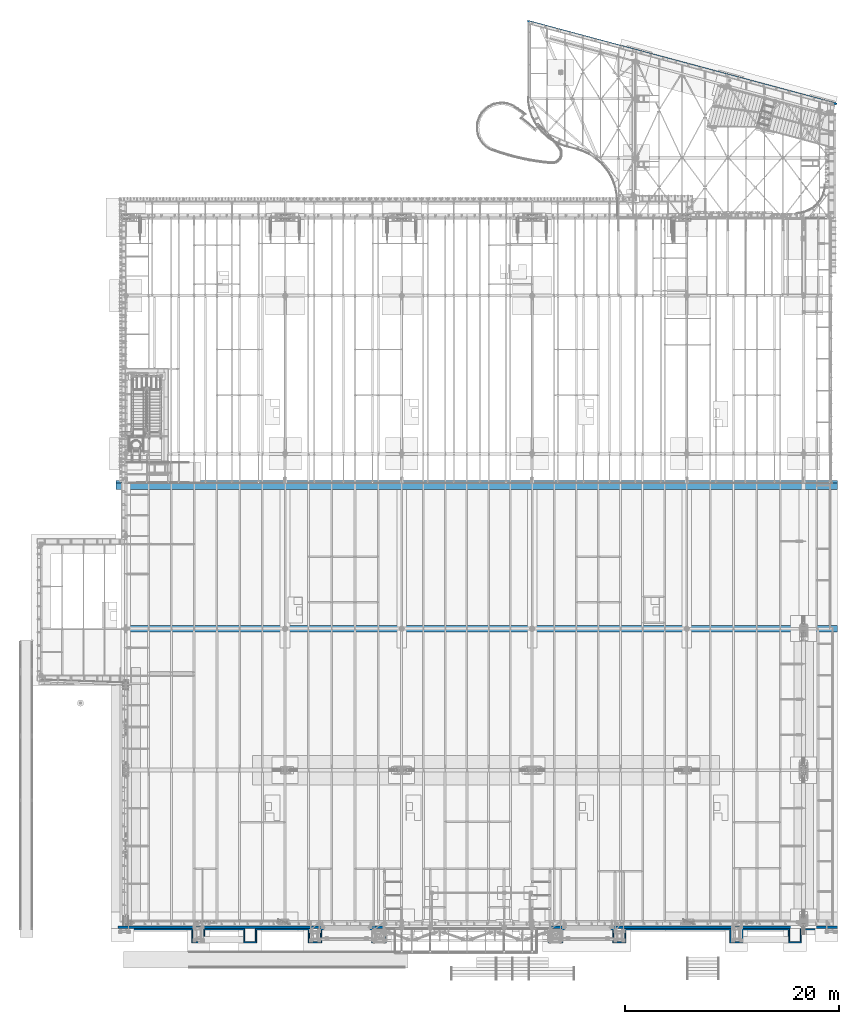
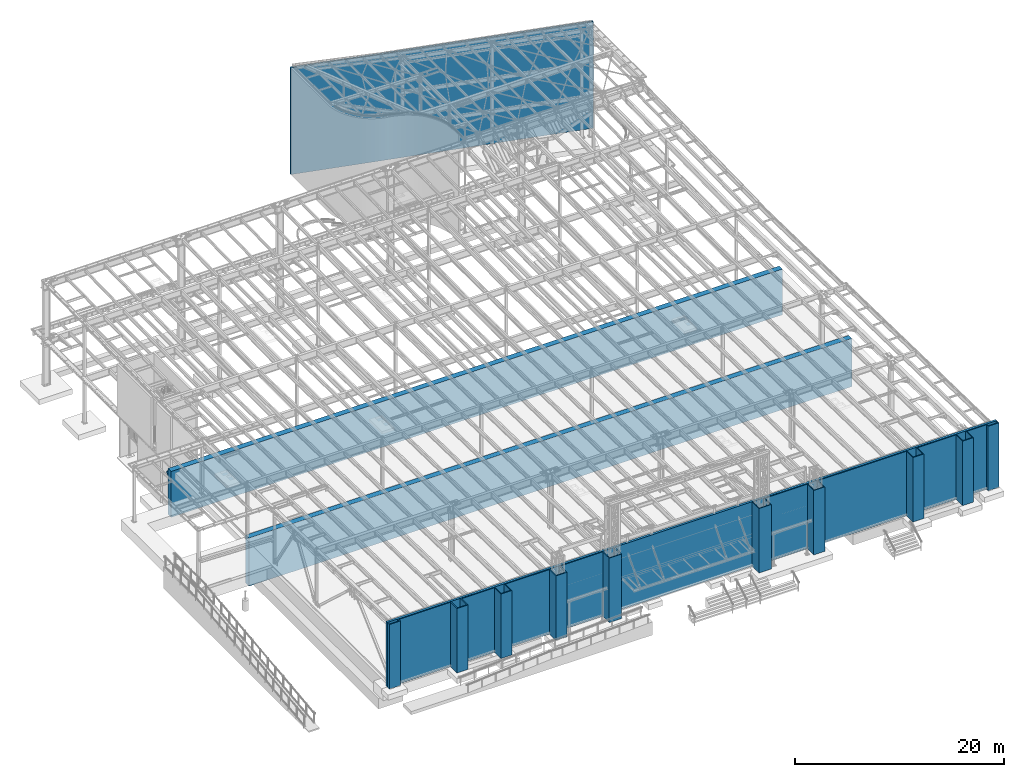
# One storey, part 1717 of 1763: 7 walls, 7 elements without a shape of their own.
"""IFC2X3 building model written with IfcOpenShell, lengths in millimetres."""

import ifcopenshell
import ifcopenshell.guid

model = None  # the IFC model being written
_history = None  # IfcOwnerHistory: only IFC2X3 demands one
_inside = {}  # id of a spatial element -> (the spatial element, [elements in it])
_under = {}  # id of a project, library or spatial element -> (it, [spatial elements below it])
_declared = {}  # id of a project -> (the project, [libraries it declares])
_typed = {}  # id of a type object -> (the type object, [elements of that type])
_made_of = {}  # id of a material, layer set ... -> (it, [elements and type objects made of it])


def new_model(schema):
    """Start an empty IFC model of exactly this schema.

    Asked for "IFC4X3", IfcOpenShell would pick the latest addendum, in which some entities
    have other attributes; the version numbers below select the first issue.
    IFC2X3 requires an IfcOwnerHistory on every rooted entity: one is made here for all.
    """
    global model, _history
    if schema == "IFC4X3":
        model = ifcopenshell.file(schema_version=(4, 3, 0, 0))
    else:
        model = ifcopenshell.file(schema=schema)
    _inside.clear()
    _under.clear()
    _declared.clear()
    _typed.clear()
    _made_of.clear()
    _history = None
    if model.schema == "IFC2X3":
        org = make("IfcOrganization", Name="unknown")
        user = make(
            "IfcPersonAndOrganization",
            ThePerson=make("IfcPerson", FamilyName="unknown"),
            TheOrganization=org,
        )
        app = make(
            "IfcApplication",
            ApplicationDeveloper=org,
            Version="unknown",
            ApplicationFullName="unknown",
            ApplicationIdentifier="unknown",
        )
        _history = make(
            "IfcOwnerHistory",
            OwningUser=user,
            OwningApplication=app,
            ChangeAction="ADDED",
            CreationDate=0,
        )
    return model


def make(cls, **values):
    """One entity of the class cls with the attributes given. An attribute that is None is left unset."""
    return model.create_entity(
        cls, **{name: value for name, value in values.items() if value is not None}
    )


def rooted(cls, **values):
    """An entity with a GlobalId (a new one), such as an element, a storey or a relation."""
    return make(cls, GlobalId=ifcopenshell.guid.new(), OwnerHistory=_history, **values)


def si_unit(unit_type, name, prefix=None):
    """IfcSIUnit, for example si_unit("LENGTHUNIT", "METRE", prefix="MILLI")."""
    return make("IfcSIUnit", UnitType=unit_type, Prefix=prefix, Name=name)


def assignment(units):
    """IfcUnitAssignment: the units of a project."""
    return None if units is None else make("IfcUnitAssignment", Units=units)


def point(xyz):
    """IfcCartesianPoint."""
    return None if xyz is None else make("IfcCartesianPoint", Coordinates=xyz)


def direction(xyz):
    """IfcDirection."""
    return None if xyz is None else make("IfcDirection", DirectionRatios=xyz)


def frame(location, z_axis=None, x_axis=None):
    """IfcAxis2Placement3D, a coordinate frame: its origin and axes. An axis left out is left unset."""
    return make(
        "IfcAxis2Placement3D",
        Location=point(location),
        Axis=direction(z_axis),
        RefDirection=direction(x_axis),
    )


def origin_with_axes():
    """The frame at (0, 0, 0) with the z axis (0, 0, 1) and the x axis (1, 0, 0) written out."""
    return frame((0.0, 0.0, 0.0), z_axis=(0.0, 0.0, 1.0), x_axis=(1.0, 0.0, 0.0))


def place(relative_to, where):
    """IfcLocalPlacement: puts the frame where relative to a parent placement (None: the world)."""
    return make(
        "IfcLocalPlacement", PlacementRelTo=relative_to, RelativePlacement=where
    )


def context(
    kind, dimensions, precision=None, world=None, true_north=None, identifier=None
):
    """IfcGeometricRepresentationContext, for example the 3D "Model" context."""
    return make(
        "IfcGeometricRepresentationContext",
        ContextIdentifier=identifier,
        ContextType=kind,
        CoordinateSpaceDimension=dimensions,
        Precision=precision,
        WorldCoordinateSystem=world,
        TrueNorth=true_north,
    )


def subcontext(parent, identifier, kind, view, scale=None):
    """IfcGeometricRepresentationSubContext, for example "Body" below "Model"."""
    return make(
        "IfcGeometricRepresentationSubContext",
        ContextIdentifier=identifier,
        ContextType=kind,
        ParentContext=parent,
        TargetScale=scale,
        TargetView=view,
    )


def project(units=None, contexts=None):
    """IfcProject with its units and contexts."""
    return rooted(
        "IfcProject",
        Name="project",
        RepresentationContexts=contexts,
        UnitsInContext=assignment(units),
    )


def spatial(cls, under=None, at=None, **own):
    """A site, building, storey or space (cls), placed at a placement, below another one or the project."""
    s = rooted(cls, ObjectPlacement=at, **own)
    if under is not None:
        _under.setdefault(under.id(), (under, []))[1].append(s)
    return s


def faces_of(points, faces, orient=None, outer=None):
    """IfcFace entities. A face is a list of loops; a loop is a list of indices into points, from 0.

    orient and outer hold one flag for each loop. By default every Orientation is true, the
    first loop of a face is its IfcFaceOuterBound and the others are IfcFaceBound.
    """
    made = []
    for i, loops in enumerate(faces):
        bounds = []
        for j, loop in enumerate(loops):
            is_outer = j == 0 if outer is None else outer[i][j]
            bounds.append(
                make(
                    "IfcFaceOuterBound" if is_outer else "IfcFaceBound",
                    Bound=make("IfcPolyLoop", Polygon=[points[k] for k in loop]),
                    Orientation=True if orient is None else orient[i][j],
                )
            )
        made.append(make("IfcFace", Bounds=bounds))
    return made


def faceted_brep(points, faces, orient=None, outer=None, voids=None):
    """IfcFacetedBrep: a solid bounded by flat faces; with voids (closed shells), ...WithVoids."""
    shared = [point(p) for p in points]
    hull = make("IfcClosedShell", CfsFaces=faces_of(shared, faces, orient, outer))
    if voids is None:
        return make("IfcFacetedBrep", Outer=hull)
    return make(
        "IfcFacetedBrepWithVoids",
        Outer=hull,
        Voids=[
            make(cls, CfsFaces=faces_of(shared, fs, o, b)) for cls, fs, o, b in voids
        ],
    )


def shape(context_of_items, identifier, shape_type, items):
    """IfcShapeRepresentation: the items that make up one representation, for example the "Body"."""
    return make(
        "IfcShapeRepresentation",
        ContextOfItems=context_of_items,
        RepresentationIdentifier=identifier,
        RepresentationType=shape_type,
        Items=items,
    )


def material(Name=None, Category=None):
    """IfcMaterial."""
    return make("IfcMaterial", Name=Name, Category=Category)


def made_of(thing, what):
    """Note that an element or type object is made of a material, layer set ...; save() writes the relation."""
    if what is not None:
        _made_of.setdefault(what.id(), (what, []))[1].append(thing)
    return thing


def type_object(cls, material=None, **own):
    """A type object (cls), such as IfcWallType, which elements share."""
    return made_of(rooted(cls, **own), material)


def element(
    cls,
    number,
    at=None,
    inside=None,
    cuts=None,
    type_object=None,
    material=None,
    context=None,
    identifier="Body",
    shape_type=None,
    held_by="IfcProductDefinitionShape",
    body=None,
    shapes=None,
    **own,
):
    """One element of the class cls, such as IfcWall. Its Tag is "e" and its number.

    at: its placement. inside: the storey or other place that contains it. cuts: it is an
    opening in that element (IfcRelVoidsElement). A single representation is given by context,
    identifier, shape_type and body (its items); several are given by shapes. held_by: the class
    of the entity that holds the representations. save() writes the other relations.
    """
    e = rooted(cls, Tag="e%d" % number, ObjectPlacement=at, **own)
    if body is not None:
        shapes = [shape(context, identifier, shape_type, body)]
    if shapes is not None:
        e.Representation = make(held_by, Representations=shapes)
    if inside is not None:
        _inside.setdefault(inside.id(), (inside, []))[1].append(e)
    if cuts is not None:
        rooted(
            "IfcRelVoidsElement", RelatingBuildingElement=cuts, RelatedOpeningElement=e
        )
    if type_object is not None:
        _typed.setdefault(type_object.id(), (type_object, []))[1].append(e)
    return made_of(e, material)


def aggregate(whole, parts):
    """IfcRelAggregates: a whole, such as a stair, and the parts it consists of."""
    return rooted("IfcRelAggregates", RelatingObject=whole, RelatedObjects=parts)


def save(model, path):
    """Write the relations noted so far, then the file.

    IfcRelAggregates (storeys below a building ...), IfcRelContainedInSpatialStructure (elements
    in a storey), IfcRelDefinesByType, IfcRelAssociatesMaterial and IfcRelDeclares: one each for
    every whole, place, type object, material and project.
    """
    for whole, parts in _under.values():
        aggregate(whole, parts)
    for where, things in _inside.values():
        rooted(
            "IfcRelContainedInSpatialStructure",
            RelatedElements=things,
            RelatingStructure=where,
        )
    for kind, things in _typed.values():
        rooted("IfcRelDefinesByType", RelatedObjects=things, RelatingType=kind)
    for what, things in _made_of.values():
        rooted("IfcRelAssociatesMaterial", RelatedObjects=things, RelatingMaterial=what)
    for by, libraries in _declared.values():
        rooted("IfcRelDeclares", RelatingContext=by, RelatedDefinitions=libraries)
    model.write(path)


model = new_model("IFC2X3")

# Units and contexts
model_context = context("Model", 3, precision=1e-05, world=origin_with_axes())
body_context = subcontext(model_context, "Body", "Model", "MODEL_VIEW")
ifc_project = project(units=[si_unit("LENGTHUNIT", "METRE", prefix="MILLI"), si_unit("AREAUNIT", "SQUARE_METRE"), si_unit("VOLUMEUNIT", "CUBIC_METRE"), si_unit("MASSUNIT", "GRAM", prefix="KILO"), si_unit("TIMEUNIT", "SECOND"), si_unit("PLANEANGLEUNIT", "RADIAN"), si_unit("SOLIDANGLEUNIT", "STERADIAN"), si_unit("THERMODYNAMICTEMPERATUREUNIT", "DEGREE_CELSIUS"), si_unit("LUMINOUSINTENSITYUNIT", "LUMEN")], contexts=[model_context])

# Site, building, storey
site_placement = place(None, origin_with_axes())
site = spatial("IfcSite", under=ifc_project, at=site_placement, CompositionType="ELEMENT")
building_placement = place(site_placement, origin_with_axes())
building = spatial("IfcBuilding", under=site, at=building_placement, Name="Undefined", CompositionType="ELEMENT")
storey_placement = place(building_placement, origin_with_axes())
storey = spatial("IfcBuildingStorey", under=building, at=storey_placement, Name="Undefined", CompositionType="ELEMENT", Elevation=0.0)

# Assembly, wall
assembly_1_placement = place(storey_placement, origin_with_axes())
assembly_1 = element("IfcElementAssembly", 1, at=assembly_1_placement, inside=storey, Name="WALL", AssemblyPlace="NOTDEFINED", PredefinedType="REINFORCEMENT_UNIT")
ifc_material = material(Name="CONCRETE/5000")
wall_type_1 = type_object("IfcWallType", PredefinedType="NOTDEFINED")
wall_1_placement = place(assembly_1_placement, frame((-54584.0372744417, 27279.6, 4654.55), z_axis=(0.0, 0.0, 1.0), x_axis=(0.0, 1.0, 0.0)))
wall_1 = element("IfcWall", 2, at=wall_1_placement, type_object=wall_type_1, material=ifc_material, Name="WALL", context=body_context, shape_type="Brep", body=[
    faceted_brep([(0.0, 33705.8, 228.6), (0.0, -33705.8, 228.6), (253.999999999996, -33705.8, 228.6), (253.999999999996, 33705.8, 228.6), (253.999999999996, -33705.8, 25.3999999999905), (253.999999999996, 33705.8, 25.3999999999905), (0.0, 33705.8, -228.6), (0.0, -33705.8, -228.6)], [[[0, 1, 2, 3]], [[3, 2, 4, 5]], [[0, 3, 5, 6]], [[1, 0, 6, 7]], [[2, 1, 7, 4]], [[6, 5, 4, 7]]]),
])
aggregate(assembly_1, [wall_1])

assembly_2_placement = place(storey_placement, origin_with_axes())
assembly_2 = element("IfcElementAssembly", 3, at=assembly_2_placement, inside=storey, Name="WALL", AssemblyPlace="NOTDEFINED", PredefinedType="REINFORCEMENT_UNIT")
wall_type_2 = type_object("IfcWallType", PredefinedType="NOTDEFINED")
wall_2_placement = place(assembly_2_placement, frame((-20929.0381052931, -14351.0000471351, 8788.4), z_axis=(0.0, 0.0, 1.0), x_axis=(0.0, -1.0, 0.0)))
wall_2 = element("IfcWall", 4, at=wall_2_placement, type_object=wall_type_2, material=ifc_material, Name="WALL", context=body_context, shape_type="Brep", body=[
    faceted_brep([(0.0, -50.7999999999993, -3759.2), (0.0, -50.7999999999993, 3759.2), (0.0, 50.7999999999993, 3759.2), (0.0, 50.7999999999993, -3759.2), (406.399993896484, 50.7999999999993, 3759.2), (406.399993896484, 50.7999999999993, -3759.2), (304.799993896486, -50.7999999999993, -3759.2), (304.799993896486, -50.7999999999993, 3759.2), (406.399993896484, -1168.39995117188, 3759.2), (406.399993896484, -1168.39995117188, -3759.2), (304.799993896486, -1066.79995117188, -3759.2), (304.799993896486, -1066.79995117188, 3759.2), (101.600006103516, -1168.39995117188, 3759.2), (101.600006103516, -1168.39995117188, -3759.2), (6.10351708019152e-06, -1066.79995117188, -3759.2), (6.10351708019152e-06, -1066.79995117188, 3759.2), (101.600006103516, -3302.00004882813, 3759.2), (101.600006103516, -3302.00004882813, -3759.2), (6.10351708019152e-06, -3403.60004882812, -3759.2), (6.10351708019152e-06, -3403.60004882812, 3759.2), (1320.80004882813, -3302.00004882813, 3759.2), (1320.80004882813, -3302.00004882813, -3759.2), (1219.20004882812, -3403.60004882812, -3759.2), (1219.20004882812, -3403.60004882812, 3759.2), (1320.80004882812, -4521.20048828125, 3759.2), (1320.80004882812, -4521.20048828125, -3759.2), (1219.20004882813, -4419.60048828125, -3759.2), (1219.20004882813, -4419.60048828125, 3759.2), (101.600090026855, -4521.20048828125, 3759.2), (101.600090026855, -4521.20048828125, -3759.2), (8.87552905624034e-05, -4419.60048828125, -3759.2), (8.87552905624034e-05, -4419.60048828125, 3759.2), (101.600143432617, -8788.4001953125, 3759.2), (101.600143432617, -8788.4001953125, -3759.2), (0.00014470418318524, -8890.0001953125, -3759.2), (0.00014470418318524, -8890.0001953125, 3759.2), (1320.80017089844, -8788.4001953125, 3759.2), (1320.80017089844, -8788.4001953125, -3759.2), (1219.20017089844, -8890.0001953125, -3759.2), (1219.20017089844, -8890.0001953125, 3759.2), (1320.80017089844, -10007.600390625, 3759.2), (1320.80017089844, -10007.600390625, -3759.2), (1219.20017089844, -9906.000390625, -3759.2), (1219.20017089844, -9906.000390625, 3759.2), (101.600158691406, -10007.600390625, 3759.2), (101.600158691406, -10007.600390625, -3759.2), (0.000158132184878923, -9906.000390625, -3759.2), (0.000158132184878923, -9906.000390625, 3759.2), (101.600212097168, -19710.401171875, 3759.2), (101.600212097168, -19710.401171875, -3759.2), (0.000212656390431221, -19812.001171875, -3759.2), (0.000212656390431221, -19812.001171875, 3759.2), (1320.80017089844, -19710.401171875, 3759.2), (1320.80017089844, -19710.401171875, -3759.2), (1219.20017089844, -19812.001171875, -3759.2), (1219.20017089844, -19812.001171875, 3759.2), (1320.80017089844, -20929.600390625, 3759.2), (1320.80017089844, -20929.600390625, -3759.2), (1219.20017089844, -20828.000390625, -3759.2), (1219.20017089844, -20828.000390625, 3759.2), (101.600227355957, -20929.600390625, 3759.2), (101.600227355957, -20929.600390625, -3759.2), (0.000226194963033777, -20828.000390625, -3759.2), (0.000226194963033777, -20828.000390625, 3759.2), (101.600280761719, -25603.2, 3759.2), (101.600280761719, -25603.2, -3759.2), (0.000281922713838867, -25704.8, -3759.2), (0.000281922713838867, -25704.8, 3759.2), (1320.80029296875, -25603.2, 3759.2), (1320.80029296875, -25603.2, -3759.2), (1219.20029296875, -25704.8, -3759.2), (1219.20029296875, -25704.8, 3759.2), (1320.80029296875, -26974.8015625, 3759.2), (1320.80029296875, -26974.8015625, -3759.2), (1219.20029296875, -26873.2015625, -3759.2), (1219.20029296875, -26873.2015625, 3759.2), (0.000301444000797346, -26974.8015625, 3759.2), (0.000301444000797346, -26974.8015625, -3759.2), (0.000301444000797346, -26873.2015625, 3759.2), (0.000301444000797346, -26873.2015625, -3759.2)], [[[0, 1, 2, 3]], [[3, 2, 4, 5]], [[1, 0, 6, 7]], [[5, 4, 8, 9]], [[7, 6, 10, 11]], [[9, 8, 12, 13]], [[11, 10, 14, 15]], [[13, 12, 16, 17]], [[15, 14, 18, 19]], [[17, 16, 20, 21]], [[19, 18, 22, 23]], [[21, 20, 24, 25]], [[23, 22, 26, 27]], [[25, 24, 28, 29]], [[27, 26, 30, 31]], [[29, 28, 32, 33]], [[31, 30, 34, 35]], [[33, 32, 36, 37]], [[35, 34, 38, 39]], [[37, 36, 40, 41]], [[39, 38, 42, 43]], [[41, 40, 44, 45]], [[43, 42, 46, 47]], [[45, 44, 48, 49]], [[47, 46, 50, 51]], [[49, 48, 52, 53]], [[51, 50, 54, 55]], [[53, 52, 56, 57]], [[55, 54, 58, 59]], [[57, 56, 60, 61]], [[59, 58, 62, 63]], [[61, 60, 64, 65]], [[63, 62, 66, 67]], [[65, 64, 68, 69]], [[67, 66, 70, 71]], [[69, 68, 72, 73]], [[71, 70, 74, 75]], [[73, 72, 76, 77]], [[72, 68, 64, 60, 56, 52, 48, 44, 40, 36, 32, 28, 24, 20, 16, 12, 8, 4, 2, 1, 7, 11, 15, 19, 23, 27, 31, 35, 39, 43, 47, 51, 55, 59, 63, 67, 71, 75, 78, 76]], [[75, 74, 79, 78]], [[74, 70, 66, 62, 58, 54, 50, 46, 42, 38, 34, 30, 26, 22, 18, 14, 10, 6, 0, 3, 5, 9, 13, 17, 21, 25, 29, 33, 37, 41, 45, 49, 53, 57, 61, 65, 69, 73, 77, 79]], [[78, 79, 77, 76]]]),
])
aggregate(assembly_2, [wall_2])

assembly_3_placement = place(storey_placement, origin_with_axes())
assembly_3 = element("IfcElementAssembly", 5, at=assembly_3_placement, inside=storey, Name="WALL", AssemblyPlace="NOTDEFINED", PredefinedType="REINFORCEMENT_UNIT")
wall_3_placement = place(assembly_3_placement, frame((-88061.237275215, -14350.9999881361, 8788.4), z_axis=(0.0, 0.0, 1.0), x_axis=(0.0, -1.0, 0.0)))
wall_3 = element("IfcWall", 6, at=wall_3_placement, type_object=wall_type_2, material=ifc_material, Name="WALL", context=body_context, shape_type="Brep", body=[
    faceted_brep([(0.0, -50.7999999999993, -3759.2), (0.0, -50.7999999999993, 3759.2), (0.0, 50.7999999999993, 3759.2), (0.0, 50.7999999999993, -3759.2), (304.799993896482, 50.8000000000029, 3759.2), (304.799993896482, 50.8000000000029, -3759.2), (406.399993896481, -50.8000000000029, -3759.2), (406.399993896481, -50.8000000000029, 3759.2), (304.799993896482, 1066.79995117187, 3759.2), (304.799993896482, 1066.79995117187, -3759.2), (406.399993896481, 1168.39995117187, -3759.2), (406.399993896481, 1168.39995117187, 3759.2), (6.10351344221272e-06, 1066.79995117187, 3759.2), (6.10351344221272e-06, 1066.79995117187, -3759.2), (101.600006103512, 1168.39995117187, -3759.2), (101.600006103512, 1168.39995117187, 3759.2), (6.10351344221272e-06, 6959.60029296875, 3759.2), (6.10351344221272e-06, 6959.60029296875, -3759.2), (101.600006103512, 6858.00029296875, -3759.2), (101.600006103512, 6858.00029296875, 3759.2), (1219.20004882812, 6959.60029296875, 3759.2), (1219.20004882812, 6959.60029296875, -3759.2), (1320.80004882812, 6858.00029296875, -3759.2), (1320.80004882812, 6858.00029296875, 3759.2), (1219.20004882812, 7975.60048828124, 3759.2), (1219.20004882812, 7975.60048828124, -3759.2), (1320.80004882812, 8077.20048828125, -3759.2), (1320.80004882812, 8077.20048828125, 3759.2), (8.85224635567283e-05, 7975.60048828124, 3759.2), (8.85224635567283e-05, 7975.60048828124, -3759.2), (101.600090026852, 8077.20048828125, -3759.2), (101.600090026852, 8077.20048828125, 3759.2), (0.000144937002914958, 11785.5998046875, 3759.2), (0.000144937002914958, 11785.5998046875, -3759.2), (101.600143432614, 11683.9998046875, -3759.2), (101.600143432614, 11683.9998046875, 3759.2), (1219.20017089844, 11785.5998046875, 3759.2), (1219.20017089844, 11785.5998046875, -3759.2), (1320.80017089843, 11683.9998046875, -3759.2), (1320.80017089843, 11683.9998046875, 3759.2), (1219.20017089844, 12801.6, 3759.2), (1219.20017089844, 12801.6, -3759.2), (1320.80017089843, 12903.2, -3759.2), (1320.80017089843, 12903.2, 3759.2), (0.000157572958414676, 12801.6, 3759.2), (0.000157572958414676, 12801.6, -3759.2), (101.600158691403, 12903.2, -3759.2), (101.600158691403, 12903.2, 3759.2), (0.00021321560961951, 17856.200390625, 3759.2), (0.00021321560961951, 17856.200390625, -3759.2), (101.600212097164, 17754.600390625, -3759.2), (101.600212097164, 17754.600390625, 3759.2), (1219.20017089844, 17856.200390625, 3759.2), (1219.20017089844, 17856.200390625, -3759.2), (1320.80017089843, 17754.600390625, -3759.2), (1320.80017089843, 17754.600390625, 3759.2), (1219.20017089844, 18872.199609375, 3759.2), (1219.20017089844, 18872.199609375, -3759.2), (1320.80017089843, 18973.799609375, -3759.2), (1320.80017089843, 18973.799609375, 3759.2), (0.000226194959395798, 18872.199609375, 3759.2), (0.000226194959395798, 18872.199609375, -3759.2), (101.600227355953, 18973.799609375, -3759.2), (101.600227355953, 18973.799609375, 3759.2), (0.000281922710200888, 23748.99921875, 3759.2), (0.000281922710200888, 23748.99921875, -3759.2), (101.600280761715, 23647.39921875, -3759.2), (101.600280761715, 23647.39921875, 3759.2), (1219.20029296875, 23748.99921875, 3759.2), (1219.20029296875, 23748.99921875, -3759.2), (1320.80029296875, 23647.39921875, -3759.2), (1320.80029296875, 23647.39921875, 3759.2), (1219.20029296875, 24917.40078125, 3759.2), (1219.20029296875, 24917.40078125, -3759.2), (1320.80029296875, 25019.00078125, -3759.2), (1320.80029296875, 25019.00078125, 3759.2), (0.000301444000797346, 24917.40078125, 3759.2), (0.000301444000797346, 24917.40078125, -3759.2), (0.000301444000797346, 25019.00078125, 3759.2), (0.000301444000797346, 25019.00078125, -3759.2)], [[[0, 1, 2, 3]], [[3, 2, 4, 5]], [[1, 0, 6, 7]], [[5, 4, 8, 9]], [[7, 6, 10, 11]], [[9, 8, 12, 13]], [[11, 10, 14, 15]], [[13, 12, 16, 17]], [[15, 14, 18, 19]], [[17, 16, 20, 21]], [[19, 18, 22, 23]], [[21, 20, 24, 25]], [[23, 22, 26, 27]], [[25, 24, 28, 29]], [[27, 26, 30, 31]], [[29, 28, 32, 33]], [[31, 30, 34, 35]], [[33, 32, 36, 37]], [[35, 34, 38, 39]], [[37, 36, 40, 41]], [[39, 38, 42, 43]], [[41, 40, 44, 45]], [[43, 42, 46, 47]], [[45, 44, 48, 49]], [[47, 46, 50, 51]], [[49, 48, 52, 53]], [[51, 50, 54, 55]], [[53, 52, 56, 57]], [[55, 54, 58, 59]], [[57, 56, 60, 61]], [[59, 58, 62, 63]], [[61, 60, 64, 65]], [[63, 62, 66, 67]], [[65, 64, 68, 69]], [[67, 66, 70, 71]], [[69, 68, 72, 73]], [[71, 70, 74, 75]], [[73, 72, 76, 77]], [[72, 68, 64, 60, 56, 52, 48, 44, 40, 36, 32, 28, 24, 20, 16, 12, 8, 4, 2, 1, 7, 11, 15, 19, 23, 27, 31, 35, 39, 43, 47, 51, 55, 59, 63, 67, 71, 75, 78, 76]], [[75, 74, 79, 78]], [[74, 70, 66, 62, 58, 54, 50, 46, 42, 38, 34, 30, 26, 22, 18, 14, 10, 6, 0, 3, 5, 9, 13, 17, 21, 25, 29, 33, 37, 41, 45, 49, 53, 57, 61, 65, 69, 73, 77, 79]], [[78, 79, 77, 76]]]),
])
aggregate(assembly_3, [wall_3])

assembly_4_placement = place(storey_placement, origin_with_axes())
assembly_4 = element("IfcElementAssembly", 7, at=assembly_4_placement, inside=storey, Name="WALL", AssemblyPlace="NOTDEFINED", PredefinedType="REINFORCEMENT_UNIT")
wall_type_3 = type_object("IfcWallType", PredefinedType="NOTDEFINED")
wall_4_placement = place(assembly_4_placement, frame((-88112.0372736903, -14223.9999881361, 8788.4), z_axis=(0.0, 0.0, 1.0), x_axis=(1.0, 0.0, 0.0)))
wall_4 = element("IfcWall", 8, at=wall_4_placement, type_object=wall_type_3, material=ifc_material, Name="WALL", context=body_context, shape_type="Brep", body=[
    faceted_brep([(6.69388100504875e-10, 126.999999999998, -3759.2), (6.69388100504875e-10, 126.999999999998, 3759.2), (67233.8031249927, 127.000000008531, 3759.2), (67233.8031249927, 127.000000008531, -3759.2), (-6.83940015733242e-10, -127.000000000002, 3759.2), (67233.8031249913, -126.999999991469, 3759.2), (-6.83940015733242e-10, -127.000000000002, -3759.2), (67233.8031249913, -126.999999991469, -3759.2)], [[[0, 1, 2, 3]], [[1, 4, 5, 2]], [[4, 6, 7, 5]], [[6, 0, 3, 7]], [[5, 7, 3, 2]], [[6, 4, 1, 0]]]),
])
aggregate(assembly_4, [wall_4])

assembly_5_placement = place(storey_placement, origin_with_axes())
assembly_5 = element("IfcElementAssembly", 9, at=assembly_5_placement, inside=storey, Name="WALL", AssemblyPlace="NOTDEFINED", PredefinedType="REINFORCEMENT_UNIT")
wall_type_4 = type_object("IfcWallType", PredefinedType="NOTDEFINED")
wall_5_placement = place(assembly_5_placement, frame((-87375.4372736983, 13690.6, 2501.9), z_axis=(0.0, 0.0, 1.0), x_axis=(1.0, 0.0, 0.0)))
wall_5 = element("IfcWall", 10, at=wall_5_placement, type_object=wall_type_4, material=ifc_material, Name="WALL", context=body_context, shape_type="Brep", body=[
    faceted_brep([(0.0, 304.799999999999, -2806.7), (0.0, 304.799999999999, 2806.7), (66497.2, 304.799999999999, 2806.7), (66497.2, 304.799999999999, -2806.7), (0.0, -304.799999999999, 2806.7), (66497.2, -304.799999999999, 2806.7), (0.0, -304.799999999999, -2806.7), (66497.2, -304.799999999999, -2806.7)], [[[0, 1, 2, 3]], [[1, 4, 5, 2]], [[4, 6, 7, 5]], [[6, 0, 3, 7]], [[5, 7, 3, 2]], [[6, 4, 1, 0]]]),
])
aggregate(assembly_5, [wall_5])

assembly_6_placement = place(storey_placement, origin_with_axes())
assembly_6 = element("IfcElementAssembly", 11, at=assembly_6_placement, inside=storey, Name="WALL", AssemblyPlace="NOTDEFINED", PredefinedType="REINFORCEMENT_UNIT")
wall_type_5 = type_object("IfcWallType", PredefinedType="NOTDEFINED")
wall_6_placement = place(assembly_6_placement, frame((-88289.8372736985, 26974.8, 2667.0), z_axis=(0.0, 0.0, 1.0), x_axis=(1.0, 0.0, 0.0)))
wall_6 = element("IfcWall", 12, at=wall_6_placement, type_object=wall_type_5, material=ifc_material, Name="WALL", context=body_context, shape_type="Brep", body=[
    faceted_brep([(0.0, 304.799999999999, -2667.0), (0.0, 304.799999999999, 2667.0), (67411.5999992567, 304.799999999999, 2667.0), (67411.5999992567, 304.799999999999, -2667.0), (0.0, -304.799999999999, 2667.0), (67411.5999992567, -304.799999999999, 2667.0), (0.0, -304.799999999999, -2667.0), (67411.5999992567, -304.799999999999, -2667.0)], [[[0, 1, 2, 3]], [[1, 4, 5, 2]], [[4, 6, 7, 5]], [[6, 0, 3, 7]], [[5, 7, 3, 2]], [[6, 4, 1, 0]]]),
])
aggregate(assembly_6, [wall_6])

assembly_7_placement = place(storey_placement, origin_with_axes())
assembly_7 = element("IfcElementAssembly", 13, at=assembly_7_placement, inside=storey, Name="WALL", AssemblyPlace="NOTDEFINED", PredefinedType="REINFORCEMENT_UNIT")
wall_type_6 = type_object("IfcWallType", PredefinedType="NOTDEFINED")
wall_7_placement = place(assembly_7_placement, frame((-49882.4924390762, 70474.7496787888, 6223.0), z_axis=(0.0, 0.0, 1.0), x_axis=(0.965917498492154, -0.258850122863906, 0.0)))
wall_7 = element("IfcWall", 14, at=wall_7_placement, type_object=wall_type_6, material=ifc_material, Name="WALL", context=body_context, shape_type="Brep", body=[
    faceted_brep([(0.00155698468734045, 95.250000000713, -6223.0), (0.00155698468734045, 95.250000000713, 6223.0), (29966.8681345363, 95.2500001059016, 6223.0), (29966.8681345363, 95.2500001059016, -6223.0), (51.0524474397389, -95.2500000005384, 6223.0), (29966.868134536, -95.2499998955464, 6223.0), (51.0524474397389, -95.2500000005384, -6223.0), (29966.868134536, -95.2499998955464, -6223.0)], [[[0, 1, 2, 3]], [[1, 4, 5, 2]], [[4, 6, 7, 5]], [[6, 0, 3, 7]], [[5, 7, 3, 2]], [[6, 4, 1, 0]]]),
])
aggregate(assembly_7, [wall_7])

save(model, "model.ifc")
